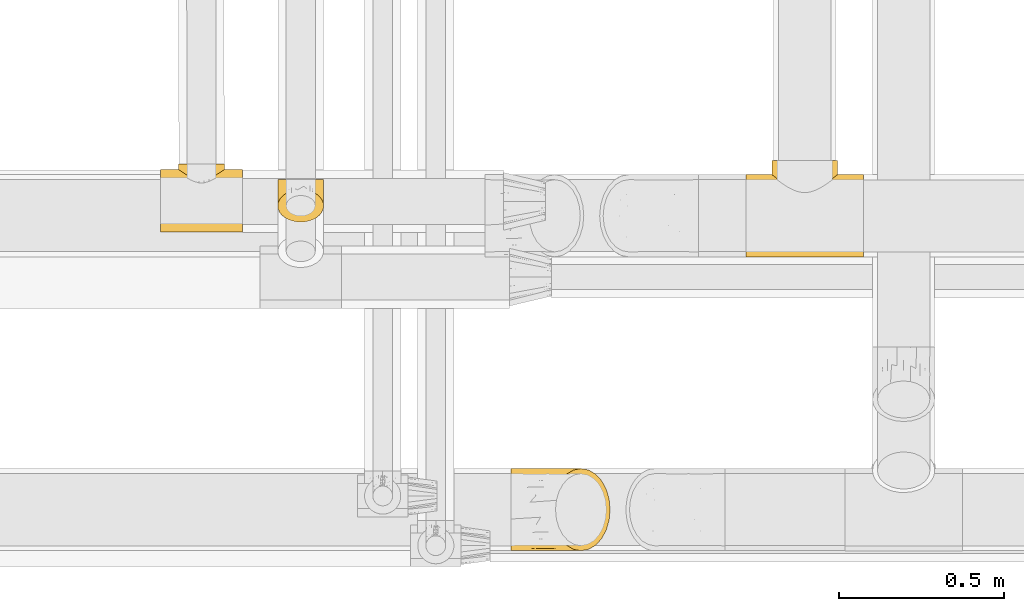
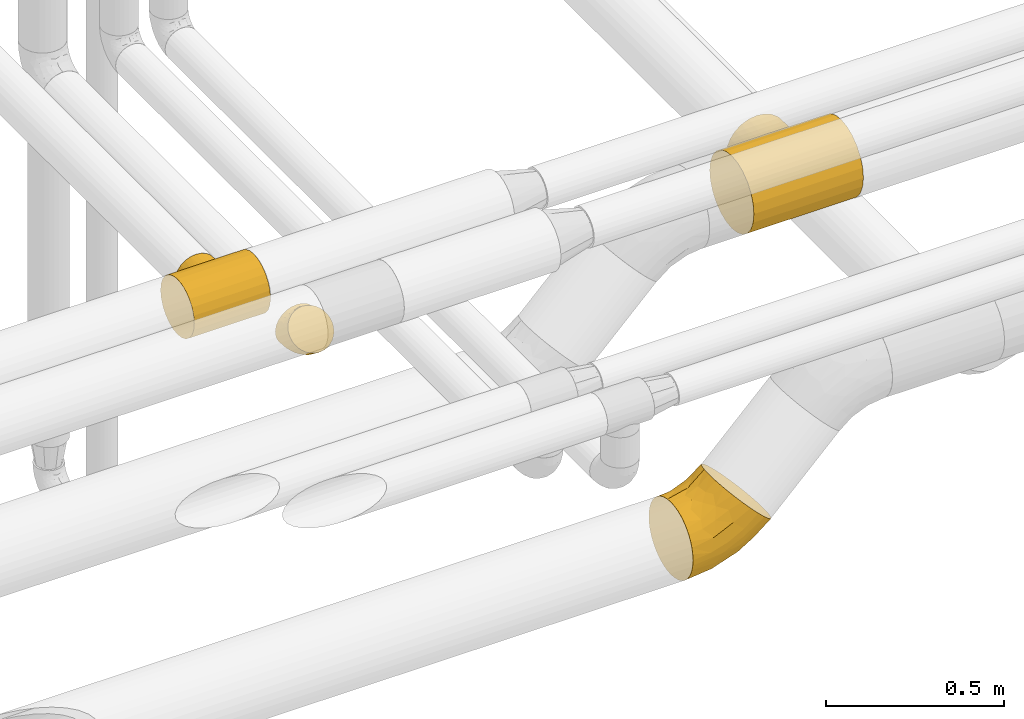
# One storey, part 185 of 827: 4 coverings.
"""IFC2X3 building model written with IfcOpenShell, lengths in millimetres."""

from ifc_helpers import new_model, entity, si_unit, converted_unit, derived_unit, direction, frame, origin, place, context, subcontext, project, spatial, faceted_brep, element, save


model = new_model("IFC2X3")

# Units and contexts
model_context = context("Model", 3, precision=0.01, world=origin(), true_north=direction((6.12303176911189e-17, 1.0)))
body_context = subcontext(model_context, "Body", "Model", "MODEL_VIEW")
ifc_project = project(units=[si_unit("LENGTHUNIT", "METRE", prefix="MILLI"), si_unit("AREAUNIT", "SQUARE_METRE"), si_unit("VOLUMEUNIT", "CUBIC_METRE"), converted_unit("PLANEANGLEUNIT", "DEGREE", entity("IfcRatioMeasure", 0.0174532925199433), si_unit("PLANEANGLEUNIT", "RADIAN"), dimensions=[0, 0, 0, 0, 0, 0, 0]), si_unit("MASSUNIT", "GRAM", prefix="KILO"), derived_unit("MASSDENSITYUNIT", [(si_unit("MASSUNIT", "GRAM", prefix="KILO"), 1), (si_unit("LENGTHUNIT", "METRE"), -3)]), derived_unit("MOMENTOFINERTIAUNIT", [(si_unit("LENGTHUNIT", "METRE"), 4)]), si_unit("TIMEUNIT", "SECOND"), si_unit("FREQUENCYUNIT", "HERTZ"), si_unit("THERMODYNAMICTEMPERATUREUNIT", "DEGREE_CELSIUS"), derived_unit("THERMALTRANSMITTANCEUNIT", [(si_unit("MASSUNIT", "GRAM", prefix="KILO"), 1), (si_unit("THERMODYNAMICTEMPERATUREUNIT", "KELVIN"), -1), (si_unit("TIMEUNIT", "SECOND"), -3)]), derived_unit("VOLUMETRICFLOWRATEUNIT", [(si_unit("LENGTHUNIT", "METRE"), 3), (si_unit("TIMEUNIT", "SECOND"), -1)]), derived_unit("MASSFLOWRATEUNIT", [(si_unit("MASSUNIT", "GRAM", prefix="KILO"), 1), (si_unit("TIMEUNIT", "SECOND"), -1)]), derived_unit("ROTATIONALFREQUENCYUNIT", [(si_unit("TIMEUNIT", "SECOND"), -1)]), si_unit("ELECTRICCURRENTUNIT", "AMPERE"), si_unit("ELECTRICVOLTAGEUNIT", "VOLT"), si_unit("POWERUNIT", "WATT"), si_unit("FORCEUNIT", "NEWTON", prefix="KILO"), si_unit("ILLUMINANCEUNIT", "LUX"), si_unit("LUMINOUSFLUXUNIT", "LUMEN"), si_unit("LUMINOUSINTENSITYUNIT", "CANDELA"), derived_unit("USERDEFINED", [(si_unit("MASSUNIT", "GRAM", prefix="KILO"), -1), (si_unit("LENGTHUNIT", "METRE"), -2), (si_unit("TIMEUNIT", "SECOND"), 3), (si_unit("LUMINOUSFLUXUNIT", "LUMEN"), 1)]), derived_unit("LINEARVELOCITYUNIT", [(si_unit("LENGTHUNIT", "METRE"), 1), (si_unit("TIMEUNIT", "SECOND"), -1)]), si_unit("PRESSUREUNIT", "PASCAL"), derived_unit("USERDEFINED", [(si_unit("LENGTHUNIT", "METRE"), -2), (si_unit("MASSUNIT", "GRAM", prefix="KILO"), 1), (si_unit("TIMEUNIT", "SECOND"), -2)]), derived_unit("LINEARFORCEUNIT", [(si_unit("MASSUNIT", "GRAM", prefix="KILO"), 1), (si_unit("LENGTHUNIT", "METRE"), 1), (si_unit("TIMEUNIT", "SECOND"), -2), (si_unit("LENGTHUNIT", "METRE"), -1)]), derived_unit("PLANARFORCEUNIT", [(si_unit("MASSUNIT", "GRAM", prefix="KILO"), 1), (si_unit("LENGTHUNIT", "METRE"), 1), (si_unit("TIMEUNIT", "SECOND"), -2), (si_unit("LENGTHUNIT", "METRE"), -2)])], contexts=[model_context])

# Site, building, storey
site_placement = place(None, origin())
site = spatial("IfcSite", under=ifc_project, at=site_placement, CompositionType="ELEMENT")
building_placement = place(site_placement, origin())
building = spatial("IfcBuilding", under=site, at=building_placement, CompositionType="ELEMENT")
storey_placement = place(building_placement, frame((0.0, 0.0, 28200.0)))
storey = spatial("IfcBuildingStorey", under=building, at=storey_placement, Name="08", CompositionType="ELEMENT", Elevation=28200.0)

# Coverings
covering_1_placement = place(storey_placement, frame((37570.29, 7140.06, 2773.76)))
element("IfcCovering", 1, at=covering_1_placement, inside=storey, Name=":ADSK_", ObjectType=":ADSK_", PredefinedType="INSULATION", context=body_context, shape_type="Brep", body=[
    faceted_brep([(0.0, 63.87, 18.29), (0.0, 38.08, 38.08), (0.0, 18.28, 63.88), (0.0, 5.84, 93.92), (0.0, 1.6, 126.15), (0.0, 5.84, 158.39), (0.0, 18.28, 188.43), (0.01, 38.08, 214.22), (0.01, 63.87, 234.02), (0.01, 93.91, 246.46), (0.01, 126.15, 250.7), (0.01, 158.38, 246.46), (0.01, 188.42, 234.02), (0.01, 214.22, 214.22), (0.01, 224.11, 201.33), (0.0, 234.01, 188.43), (0.0, 240.23, 173.41), (0.0, 246.45, 158.39), (0.0, 248.57, 142.27), (0.0, 250.7, 126.15), (0.0, 248.57, 110.04), (0.0, 246.45, 93.92), (0.0, 240.23, 78.9), (0.0, 234.01, 63.88), (0.0, 224.11, 50.98), (0.0, 214.22, 38.08), (0.0, 188.42, 18.29), (0.0, 158.38, 5.85), (0.0, 126.15, 1.6), (0.0, 93.91, 5.85), (356.01, 93.91, 246.45), (356.01, 63.87, 234.01), (356.01, 38.08, 214.22), (356.0, 18.28, 188.42), (356.0, 5.84, 158.38), (356.0, 1.6, 126.15), (356.0, 5.84, 93.91), (356.0, 18.28, 63.87), (356.0, 38.08, 38.08), (356.0, 63.87, 18.28), (356.0, 93.91, 5.84), (356.0, 126.15, 1.6), (356.0, 158.38, 5.84), (356.0, 188.42, 18.28), (356.0, 214.22, 38.08), (356.0, 224.11, 50.97), (356.0, 234.01, 63.87), (356.0, 240.23, 78.89), (356.0, 246.45, 93.91), (356.0, 248.57, 110.03), (356.0, 250.7, 126.15), (356.0, 248.57, 142.26), (356.0, 246.45, 158.38), (356.0, 240.23, 173.4), (356.0, 234.01, 188.42), (356.01, 224.11, 201.32), (356.01, 214.22, 214.22), (356.01, 188.42, 234.01), (356.01, 158.38, 246.45), (356.01, 126.15, 250.7), (194.3, 203.27, 223.95), (178.01, 201.52, 225.3), (209.64, 207.89, 220.12), (236.25, 221.41, 206.39), (223.62, 214.25, 214.18), (247.53, 228.69, 196.84), (90.44, 241.69, 172.66), (275.79, 249.61, 142.52), (161.71, 203.27, 223.95), (146.38, 207.89, 220.12), (78.85, 250.7, 126.15), (80.21, 249.61, 142.52), (132.39, 214.25, 214.18), (119.76, 221.41, 206.39), (108.48, 228.69, 196.84), (257.37, 235.6, 185.58), (265.57, 241.69, 172.65), (277.15, 250.7, 126.15), (271.83, 246.5, 158.2), (98.64, 235.6, 185.58), (84.18, 246.5, 158.2), (271.83, 246.5, 94.1), (275.79, 249.61, 109.77), (257.37, 235.6, 66.72), (265.57, 241.69, 79.64), (247.52, 228.69, 55.46), (80.21, 249.61, 109.78), (84.18, 246.5, 94.1), (98.64, 235.6, 66.72), (108.48, 228.69, 55.46), (90.43, 241.69, 79.65), (236.25, 221.41, 45.91), (223.62, 214.25, 38.12), (209.63, 207.89, 32.18), (194.29, 203.27, 28.35), (178.0, 201.52, 27.0), (119.76, 221.41, 45.91), (132.38, 214.25, 38.12), (146.37, 207.89, 32.18), (161.71, 203.27, 28.35), (263.87, 294.15, 175.72), (273.78, 294.15, 151.81), (277.15, 294.15, 126.15), (273.77, 294.15, 100.49), (263.87, 294.15, 76.57), (248.11, 294.15, 56.04), (227.58, 294.15, 40.28), (203.66, 294.15, 30.38), (178.0, 294.15, 27.0), (152.34, 294.15, 30.38), (128.43, 294.15, 40.28), (107.89, 294.15, 56.04), (92.14, 294.15, 76.58), (82.23, 294.15, 100.49), (78.85, 294.15, 126.15), (82.23, 294.15, 151.81), (92.14, 294.15, 175.73), (107.9, 294.15, 196.26), (128.43, 294.15, 212.02), (152.34, 294.15, 221.92), (178.01, 294.15, 225.3), (203.67, 294.15, 221.92), (227.58, 294.15, 212.02), (248.11, 294.15, 196.26)], [[[0, 1, 2, 3, 4, 5, 6, 7, 8, 9, 10, 11, 12, 13, 14, 15, 16, 17, 18, 19, 20, 21, 22, 23, 24, 25, 26, 27, 28, 29]], [[30, 31, 32, 33, 34, 35, 36, 37, 38, 39, 40, 41, 42, 43, 44, 45, 46, 47, 48, 49, 50, 51, 52, 53, 54, 55, 56, 57, 58, 59]], [[6, 33, 32, 7]], [[4, 35, 34, 5]], [[5, 34, 33, 6]], [[8, 31, 30, 9]], [[9, 30, 59, 10]], [[7, 32, 31, 8]], [[11, 58, 57, 12]], [[60, 61, 57]], [[58, 11, 10, 59]], [[57, 62, 60]], [[56, 63, 64]], [[56, 55, 63]], [[63, 55, 65]], [[64, 62, 56]], [[66, 17, 16]], [[56, 62, 57]], [[67, 52, 51]], [[57, 61, 12]], [[61, 68, 12]], [[69, 13, 12]], [[70, 18, 71]], [[13, 72, 73]], [[72, 13, 69]], [[74, 15, 14]], [[73, 74, 14]], [[75, 53, 76]], [[69, 12, 68]], [[53, 75, 54]], [[76, 53, 52]], [[75, 65, 54]], [[54, 65, 55]], [[50, 77, 51]], [[18, 70, 19]], [[67, 78, 52]], [[67, 51, 77]], [[52, 78, 76]], [[74, 79, 15]], [[79, 16, 15]], [[16, 79, 66]], [[14, 13, 73]], [[80, 71, 17]], [[71, 18, 17]], [[80, 17, 66]], [[50, 49, 77]], [[70, 20, 19]], [[48, 81, 82]], [[82, 49, 48]], [[46, 83, 47]], [[84, 47, 83]], [[46, 85, 83]], [[48, 84, 81]], [[70, 86, 20]], [[86, 87, 21]], [[23, 88, 89]], [[21, 90, 22]], [[90, 21, 87]], [[22, 88, 23]], [[44, 91, 45]], [[91, 44, 92]], [[93, 92, 44]], [[44, 43, 93]], [[84, 48, 47]], [[26, 43, 42, 27]], [[94, 43, 95]], [[43, 94, 93]], [[26, 95, 43]], [[86, 21, 20]], [[42, 41, 28, 27]], [[96, 24, 89]], [[96, 97, 25]], [[85, 46, 45]], [[89, 24, 23]], [[24, 96, 25]], [[97, 98, 25]], [[98, 99, 26]], [[77, 49, 82]], [[95, 26, 99]], [[98, 26, 25]], [[88, 22, 90]], [[85, 45, 91]], [[29, 40, 39, 0]], [[0, 39, 38, 1]], [[41, 40, 29, 28]], [[2, 37, 36, 3]], [[3, 36, 35, 4]], [[1, 38, 37, 2]], [[100, 101, 102, 103, 104, 105, 106, 107, 108, 109, 110, 111, 112, 113, 114, 115, 116, 117, 118, 119, 120, 121, 122, 123]], [[67, 102, 101]], [[100, 123, 75]], [[78, 101, 100]], [[67, 77, 102]], [[76, 78, 100]], [[75, 76, 100]], [[67, 101, 78]], [[123, 65, 75]], [[65, 123, 63]], [[63, 123, 122]], [[64, 122, 121]], [[60, 121, 120]], [[63, 122, 64]], [[121, 60, 62]], [[62, 64, 121]], [[60, 120, 61]], [[68, 120, 119]], [[119, 118, 72]], [[117, 73, 118]], [[117, 74, 73]], [[61, 120, 68]], [[69, 68, 119]], [[119, 72, 69]], [[118, 73, 72]], [[79, 117, 116]], [[80, 116, 115]], [[71, 115, 114]], [[66, 79, 116]], [[71, 80, 115]], [[70, 71, 114]], [[66, 116, 80]], [[117, 79, 74]], [[86, 114, 113]], [[87, 113, 112]], [[88, 112, 111]], [[86, 70, 114]], [[90, 87, 112]], [[88, 90, 112]], [[86, 113, 87]], [[111, 89, 88]], [[89, 111, 96]], [[96, 111, 110]], [[97, 110, 109]], [[99, 109, 108]], [[96, 110, 97]], [[109, 99, 98]], [[98, 97, 109]], [[99, 108, 95]], [[94, 108, 107]], [[107, 106, 92]], [[105, 91, 106]], [[105, 85, 91]], [[95, 108, 94]], [[93, 94, 107]], [[107, 92, 93]], [[106, 91, 92]], [[83, 105, 104]], [[81, 104, 103]], [[82, 103, 102]], [[84, 83, 104]], [[82, 81, 103]], [[77, 82, 102]], [[84, 104, 81]], [[105, 83, 85]]]),
])
covering_2_placement = place(storey_placement, frame((36148.99, 7245.63, 2778.95)))
element("IfcCovering", 2, at=covering_2_placement, inside=storey, Name=":ADSK_", ObjectType=":ADSK_", PredefinedType="INSULATION", context=body_context, shape_type="Brep", body=[
    faceted_brep([(44.46, 96.07, 149.8), (32.45, 91.53, 145.26), (21.93, 85.42, 139.16), (13.29, 77.98, 131.71), (6.88, 69.49, 123.22), (2.93, 60.28, 114.01), (1.6, 50.7, 104.44), (2.93, 41.12, 94.85), (6.88, 31.91, 85.64), (13.3, 23.42, 77.15), (21.94, 15.97, 69.71), (32.47, 9.87, 63.6), (44.48, 5.33, 59.06), (57.5, 2.54, 56.27), (71.05, 1.6, 55.33), (84.6, 2.54, 56.27), (97.63, 5.34, 59.07), (109.64, 9.87, 63.61), (120.16, 15.98, 69.71), (128.8, 23.43, 77.16), (135.21, 31.92, 85.65), (139.16, 41.13, 94.86), (140.5, 50.7, 104.44), (139.16, 60.29, 114.02), (135.21, 69.5, 123.23), (128.79, 77.99, 131.72), (120.15, 85.43, 139.16), (109.62, 91.54, 145.27), (97.62, 96.08, 149.81), (84.59, 98.87, 152.6), (71.05, 99.81, 153.54), (57.49, 98.87, 152.6), (71.05, 131.31, 140.5), (89.02, 131.31, 138.13), (105.77, 131.31, 131.19), (120.15, 131.31, 120.15), (131.19, 131.31, 105.77), (138.13, 131.31, 89.02), (140.5, 131.31, 71.05), (138.13, 131.31, 53.07), (131.19, 131.31, 36.32), (120.15, 131.31, 21.94), (105.77, 131.31, 10.9), (89.02, 131.31, 3.96), (71.05, 131.31, 1.6), (53.07, 131.31, 3.96), (36.32, 131.31, 10.9), (21.94, 131.31, 21.94), (10.9, 131.31, 36.32), (3.96, 131.31, 53.07), (1.6, 131.31, 71.05), (3.96, 131.31, 89.02), (10.9, 131.31, 105.77), (21.94, 131.31, 120.15), (36.32, 131.31, 131.19), (53.07, 131.31, 138.13), (10.96, 88.93, 42.38), (71.05, 83.83, 7.85), (58.64, 99.89, 5.44), (29.89, 95.08, 19.01), (45.12, 97.97, 9.76), (55.8, 68.52, 14.48), (18.48, 100.53, 28.65), (19.3, 67.5, 37.97), (51.71, 34.21, 32.65), (40.19, 63.13, 22.55), (4.96, 79.52, 60.0), (29.3, 66.5, 28.42), (1.6, 74.31, 86.32), (1.6, 88.06, 80.62), (1.6, 101.81, 74.93), (10.82, 54.57, 57.81), (1.6, 115.28, 73.16), (18.25, 40.23, 54.57), (28.13, 40.29, 43.13), (39.32, 35.5, 37.67), (71.05, 39.59, 26.17), (1.6, 62.51, 95.38), (3.1, 83.48, 97.66), (4.91, 115.07, 93.69), (12.3, 101.86, 113.94), (14.54, 90.93, 123.49), (24.31, 98.32, 131.81), (3.76, 96.7, 94.66), (22.31, 111.85, 123.53), (34.74, 109.92, 134.6), (7.16, 84.35, 112.1), (58.74, 120.06, 140.81), (45.08, 119.55, 136.87), (49.04, 108.29, 142.78), (71.05, 114.27, 143.89), (3.24, 72.24, 105.61), (13.98, 117.58, 111.91), (83.34, 120.07, 140.8), (93.04, 108.29, 142.78), (97.0, 119.55, 136.88), (134.92, 84.36, 112.12), (138.99, 83.5, 97.68), (138.32, 96.72, 94.67), (140.5, 88.06, 80.62), (117.77, 98.33, 131.82), (119.76, 111.86, 123.55), (107.33, 109.92, 134.61), (137.18, 115.07, 93.69), (140.5, 115.28, 73.16), (128.1, 117.57, 111.92), (129.78, 101.87, 113.96), (138.85, 72.25, 105.62), (127.38, 89.86, 124.49), (140.5, 62.51, 95.38), (140.5, 101.81, 74.93), (140.5, 74.31, 86.32), (131.27, 54.58, 57.82), (131.13, 88.9, 42.39), (137.13, 79.52, 60.0), (113.98, 40.3, 43.13), (113.47, 66.86, 28.83), (122.8, 67.52, 37.98), (112.2, 95.1, 19.01), (123.62, 100.55, 28.66), (83.46, 99.94, 5.43), (86.3, 68.54, 14.48), (96.98, 97.96, 9.77), (123.85, 40.24, 54.58), (101.92, 63.13, 22.56), (90.4, 34.21, 32.65), (102.85, 29.15, 42.06)], [[[0, 1, 2, 3, 4, 5, 6, 7, 8, 9, 10, 11, 12, 13, 14, 15, 16, 17, 18, 19, 20, 21, 22, 23, 24, 25, 26, 27, 28, 29, 30, 31]], [[32, 33, 34, 35, 36, 37, 38, 39, 40, 41, 42, 43, 44, 45, 46, 47, 48, 49, 50, 51, 52, 53, 54, 55]], [[49, 48, 56]], [[44, 57, 58]], [[59, 46, 60]], [[61, 60, 58]], [[62, 63, 56]], [[61, 64, 65]], [[46, 59, 47]], [[8, 7, 66]], [[63, 62, 67]], [[66, 68, 69, 70]], [[9, 8, 71]], [[49, 70, 72, 50]], [[70, 49, 66]], [[73, 74, 10]], [[63, 71, 56]], [[75, 65, 64]], [[64, 61, 76]], [[76, 13, 64]], [[73, 10, 9]], [[75, 74, 67]], [[75, 11, 74]], [[13, 76, 14]], [[61, 65, 60]], [[62, 48, 47]], [[61, 58, 57]], [[49, 56, 66]], [[56, 71, 66]], [[7, 6, 77, 68]], [[71, 63, 73]], [[68, 66, 7]], [[67, 59, 65]], [[74, 73, 63]], [[74, 11, 10]], [[71, 73, 9]], [[59, 67, 62]], [[64, 13, 12]], [[76, 61, 57]], [[8, 66, 71]], [[59, 60, 65]], [[45, 60, 46]], [[48, 62, 56]], [[59, 62, 47]], [[60, 45, 58]], [[44, 58, 45]], [[64, 12, 75]], [[11, 75, 12]], [[75, 67, 65]], [[63, 67, 74]], [[69, 68, 78]], [[70, 79, 72]], [[80, 81, 82]], [[79, 70, 83]], [[54, 84, 85]], [[84, 82, 85]], [[83, 86, 80]], [[82, 84, 80]], [[87, 32, 55]], [[88, 85, 89]], [[78, 86, 83]], [[0, 31, 89]], [[85, 88, 54]], [[31, 90, 89]], [[86, 78, 91]], [[92, 84, 53]], [[82, 1, 85]], [[82, 81, 2]], [[81, 80, 86]], [[86, 91, 4]], [[77, 5, 91]], [[88, 87, 55]], [[80, 92, 79]], [[77, 6, 5]], [[92, 80, 84]], [[30, 90, 31]], [[54, 53, 84]], [[0, 85, 1]], [[82, 2, 1]], [[52, 51, 79]], [[89, 85, 0]], [[4, 91, 5]], [[80, 79, 83]], [[3, 86, 4]], [[53, 52, 92]], [[51, 72, 79]], [[79, 92, 52]], [[78, 83, 69]], [[68, 91, 78]], [[91, 68, 77]], [[87, 89, 90]], [[54, 88, 55]], [[89, 87, 88]], [[32, 87, 90]], [[51, 50, 72]], [[86, 3, 81]], [[2, 81, 3]], [[83, 70, 69]], [[93, 94, 95]], [[95, 34, 33]], [[90, 93, 32]], [[96, 97, 98]], [[97, 99, 98]], [[100, 101, 102]], [[103, 104, 37]], [[105, 101, 106]], [[98, 103, 106]], [[96, 107, 97]], [[102, 101, 34]], [[103, 37, 36]], [[90, 29, 94]], [[106, 108, 96]], [[94, 29, 28]], [[103, 105, 106]], [[94, 28, 102]], [[24, 96, 25]], [[35, 101, 105]], [[27, 26, 100]], [[25, 96, 108]], [[27, 100, 102]], [[107, 24, 23]], [[27, 102, 28]], [[100, 108, 106]], [[106, 96, 98]], [[95, 94, 102]], [[101, 100, 106]], [[23, 109, 107]], [[107, 96, 24]], [[34, 95, 102]], [[26, 25, 108]], [[103, 36, 105]], [[29, 90, 30]], [[110, 103, 98]], [[34, 101, 35]], [[36, 35, 105]], [[107, 111, 97]], [[109, 23, 22]], [[109, 111, 107]], [[93, 95, 33]], [[32, 93, 33]], [[94, 93, 90]], [[104, 103, 110]], [[104, 38, 37]], [[26, 108, 100]], [[99, 97, 111]], [[99, 110, 98]], [[112, 113, 114]], [[115, 116, 117]], [[118, 42, 41]], [[119, 40, 113]], [[114, 110, 99, 111]], [[39, 38, 104, 110]], [[119, 118, 41]], [[39, 114, 113]], [[43, 120, 44]], [[121, 120, 122]], [[42, 122, 43]], [[39, 113, 40]], [[19, 18, 123]], [[121, 122, 124]], [[76, 121, 125]], [[118, 124, 122]], [[21, 114, 111]], [[119, 113, 117]], [[39, 110, 114]], [[115, 123, 18]], [[18, 17, 115]], [[113, 112, 117]], [[116, 124, 118]], [[19, 123, 112]], [[114, 20, 112]], [[115, 117, 123]], [[125, 121, 124]], [[16, 125, 126]], [[15, 14, 76]], [[15, 76, 125]], [[112, 20, 19]], [[124, 115, 126]], [[121, 76, 57]], [[15, 125, 16]], [[17, 16, 126]], [[21, 111, 109, 22]], [[112, 123, 117]], [[21, 20, 114]], [[121, 57, 120]], [[118, 122, 42]], [[119, 117, 116]], [[40, 119, 41]], [[44, 120, 57]], [[43, 122, 120]], [[124, 126, 125]], [[17, 126, 115]], [[124, 116, 115]], [[119, 116, 118]]]),
])
covering_3_placement = place(storey_placement, frame((36856.37, 6248.9, 2373.9)))
element("IfcCovering", 3, at=covering_3_placement, inside=storey, Name=":ADSK_", ObjectType=":ADSK_", PredefinedType="INSULATION", context=body_context, shape_type="Brep", body=[
    faceted_brep([(1.6, 106.63, 249.06), (1.6, 126.1, 250.6), (1.6, 145.57, 249.06), (1.6, 164.57, 244.5), (1.6, 182.62, 237.02), (1.6, 199.28, 226.82), (1.6, 214.13, 214.13), (1.6, 226.82, 199.27), (1.6, 237.03, 182.61), (1.6, 244.5, 164.56), (1.6, 249.06, 145.56), (1.6, 250.6, 126.1), (1.6, 249.06, 106.62), (1.6, 244.5, 87.62), (1.6, 237.02, 69.57), (1.6, 226.82, 52.91), (1.6, 214.13, 38.06), (1.6, 199.27, 25.37), (1.6, 182.61, 15.16), (1.6, 164.56, 7.69), (1.6, 145.56, 3.13), (1.6, 126.1, 1.6), (1.6, 106.62, 3.13), (1.6, 87.62, 7.69), (1.6, 69.57, 15.17), (1.6, 52.91, 25.37), (1.6, 38.06, 38.06), (1.6, 25.37, 52.92), (1.6, 15.16, 69.58), (1.6, 7.69, 87.63), (1.6, 3.13, 106.63), (1.6, 1.6, 126.1), (1.6, 3.13, 145.57), (1.6, 7.69, 164.57), (1.6, 15.17, 182.62), (1.6, 25.37, 199.28), (1.6, 38.06, 214.13), (1.6, 52.92, 226.82), (1.6, 69.58, 237.03), (1.6, 87.63, 244.5), (128.69, 93.87, 299.0), (137.49, 63.85, 290.2), (151.48, 38.06, 276.21), (169.71, 18.28, 257.98), (190.94, 5.84, 236.75), (213.73, 1.6, 213.96), (236.51, 5.84, 191.18), (257.74, 18.28, 169.95), (275.98, 38.06, 151.71), (289.97, 63.85, 137.72), (298.76, 93.87, 128.93), (301.76, 126.1, 125.93), (298.76, 158.32, 128.93), (289.97, 188.35, 137.72), (275.98, 214.13, 151.71), (257.74, 233.92, 169.95), (236.51, 246.35, 191.18), (213.73, 250.6, 213.96), (190.94, 246.35, 236.75), (169.71, 233.92, 257.98), (151.48, 214.13, 276.21), (137.49, 188.35, 290.2), (128.69, 158.32, 299.0), (125.69, 126.1, 302.0), (227.53, 149.06, 69.24), (162.5, 157.57, 37.65), (232.64, 172.62, 80.78), (251.11, 126.1, 82.67), (87.27, 172.54, 19.51), (88.51, 205.38, 39.76), (72.31, 228.86, 62.63), (169.79, 211.39, 73.47), (132.77, 126.1, 22.37), (194.31, 126.1, 47.86), (68.0, 126.1, 6.82), (94.6, 148.92, 14.07), (224.14, 196.14, 90.2), (156.46, 188.53, 48.93), (159.73, 241.93, 118.76), (81.73, 239.97, 85.05), (98.75, 247.93, 115.3), (213.5, 224.58, 115.31), (141.47, 229.78, 84.73), (164.84, 248.4, 147.07), (116.4, 250.6, 148.93), (168.27, 250.6, 176.65), (60.12, 250.6, 131.86), (144.59, 243.25, 211.5), (102.29, 247.16, 174.55), (94.09, 237.03, 200.86), (105.15, 219.17, 235.05), (127.13, 232.82, 226.38), (45.11, 175.8, 245.41), (69.55, 148.67, 262.05), (92.2, 170.51, 266.31), (54.34, 243.33, 173.44), (107.8, 189.91, 264.83), (76.0, 195.3, 244.22), (38.6, 195.29, 233.11), (89.35, 126.1, 274.11), (53.39, 223.78, 209.38), (47.02, 126.1, 256.58), (56.49, 99.35, 256.34), (95.02, 94.07, 272.6), (135.65, 8.49, 204.31), (116.4, 1.6, 148.93), (168.27, 1.6, 176.65), (131.4, 25.02, 239.5), (87.85, 26.42, 217.85), (101.5, 48.04, 249.38), (50.41, 42.36, 224.04), (74.53, 74.96, 254.46), (36.95, 76.79, 243.81), (108.87, 73.49, 272.73), (74.09, 8.09, 176.09), (45.75, 25.62, 203.96), (60.12, 1.6, 131.86), (159.72, 10.26, 118.76), (213.49, 27.6, 115.31), (169.79, 40.79, 73.47), (224.16, 56.04, 90.22), (164.83, 3.79, 147.07), (98.75, 4.26, 115.3), (227.52, 103.13, 69.24), (88.51, 46.81, 39.76), (156.45, 63.66, 48.94), (232.65, 79.57, 80.78), (162.5, 94.61, 37.65), (141.47, 22.4, 84.73), (94.58, 103.26, 14.07), (87.27, 79.64, 19.51), (72.31, 23.32, 62.64), (81.73, 12.22, 85.06)], [[[0, 1, 2, 3, 4, 5, 6, 7, 8, 9, 10, 11, 12, 13, 14, 15, 16, 17, 18, 19, 20, 21, 22, 23, 24, 25, 26, 27, 28, 29, 30, 31, 32, 33, 34, 35, 36, 37, 38, 39]], [[40, 41, 42, 43, 44, 45, 46, 47, 48, 49, 50, 51, 52, 53, 54, 55, 56, 57, 58, 59, 60, 61, 62, 63]], [[64, 65, 66]], [[67, 52, 51]], [[68, 18, 17]], [[69, 70, 71]], [[72, 65, 73]], [[72, 74, 75]], [[17, 16, 69]], [[64, 73, 65]], [[70, 16, 15]], [[76, 66, 77]], [[78, 79, 80]], [[55, 81, 78]], [[78, 82, 79]], [[80, 13, 12]], [[76, 77, 71]], [[57, 56, 83]], [[78, 80, 83]], [[68, 69, 77]], [[77, 69, 71]], [[84, 85, 83]], [[18, 68, 19]], [[77, 65, 68]], [[69, 68, 17]], [[75, 68, 65]], [[78, 81, 82]], [[70, 69, 16]], [[68, 75, 19]], [[20, 74, 21]], [[53, 66, 76]], [[76, 71, 81]], [[54, 76, 81]], [[54, 81, 55]], [[86, 12, 11]], [[84, 80, 86]], [[80, 84, 83]], [[53, 52, 66]], [[64, 52, 67]], [[82, 70, 79]], [[81, 71, 82]], [[86, 80, 12]], [[76, 54, 53]], [[79, 14, 13]], [[14, 79, 70]], [[55, 78, 56]], [[77, 66, 65]], [[75, 20, 19]], [[72, 75, 65]], [[80, 79, 13]], [[20, 75, 74]], [[70, 82, 71]], [[14, 70, 15]], [[57, 83, 85]], [[56, 78, 83]], [[52, 64, 66]], [[73, 64, 67]], [[58, 85, 87]], [[58, 57, 85]], [[87, 85, 88]], [[89, 90, 91]], [[91, 60, 59]], [[91, 87, 89]], [[92, 93, 94]], [[2, 93, 92]], [[88, 95, 89]], [[96, 97, 94]], [[94, 97, 92]], [[98, 6, 5]], [[88, 85, 84]], [[99, 63, 62]], [[93, 62, 94]], [[61, 94, 62]], [[98, 4, 92]], [[2, 92, 3]], [[100, 8, 7]], [[87, 88, 89]], [[7, 6, 100]], [[100, 95, 8]], [[10, 95, 86]], [[98, 100, 6]], [[90, 97, 96]], [[9, 95, 10]], [[11, 10, 86]], [[93, 101, 99]], [[4, 98, 5]], [[62, 93, 99]], [[59, 58, 87]], [[1, 101, 2]], [[93, 2, 101]], [[86, 95, 88]], [[100, 90, 89]], [[4, 3, 92]], [[95, 100, 89]], [[90, 96, 60]], [[92, 97, 98]], [[90, 100, 97]], [[100, 98, 97]], [[9, 8, 95]], [[94, 61, 96]], [[86, 88, 84]], [[96, 61, 60]], [[60, 91, 90]], [[59, 87, 91]], [[102, 103, 99]], [[104, 105, 106]], [[102, 99, 101]], [[104, 107, 108]], [[109, 107, 42]], [[103, 63, 99]], [[110, 111, 112]], [[109, 111, 110]], [[0, 102, 101]], [[113, 103, 111]], [[114, 104, 108]], [[45, 44, 106]], [[104, 44, 43]], [[41, 109, 42]], [[109, 108, 107]], [[106, 44, 104]], [[104, 43, 107]], [[104, 114, 105]], [[0, 39, 102]], [[34, 115, 35]], [[115, 34, 114]], [[43, 42, 107]], [[38, 112, 39]], [[39, 112, 102]], [[37, 110, 112]], [[113, 40, 103]], [[115, 110, 36]], [[35, 115, 36]], [[116, 114, 33]], [[37, 36, 110]], [[110, 115, 108]], [[114, 34, 33]], [[109, 110, 108]], [[114, 116, 105]], [[112, 111, 102]], [[102, 111, 103]], [[32, 31, 116]], [[33, 32, 116]], [[113, 109, 41]], [[112, 38, 37]], [[109, 113, 111]], [[0, 101, 1]], [[40, 113, 41]], [[103, 40, 63]], [[114, 108, 115]], [[117, 47, 46]], [[117, 118, 47]], [[118, 119, 120]], [[121, 122, 117]], [[73, 67, 123]], [[119, 124, 125]], [[122, 121, 105]], [[106, 121, 45]], [[123, 126, 127]], [[118, 128, 119]], [[67, 51, 50]], [[129, 130, 23]], [[48, 120, 49]], [[125, 127, 126]], [[50, 126, 123]], [[73, 127, 72]], [[23, 22, 129]], [[131, 119, 128]], [[126, 50, 49]], [[130, 24, 23]], [[28, 132, 29]], [[126, 49, 120]], [[116, 31, 30]], [[131, 26, 124]], [[118, 48, 47]], [[132, 122, 29]], [[132, 131, 128]], [[121, 106, 105]], [[117, 128, 118]], [[131, 28, 27]], [[125, 126, 120]], [[124, 26, 25]], [[124, 25, 130]], [[130, 25, 24]], [[30, 122, 116]], [[129, 22, 74]], [[127, 130, 129]], [[132, 117, 122]], [[21, 74, 22]], [[127, 125, 130]], [[124, 130, 125]], [[127, 129, 72]], [[122, 105, 116]], [[48, 118, 120]], [[132, 128, 117]], [[29, 122, 30]], [[120, 119, 125]], [[119, 131, 124]], [[72, 129, 74]], [[28, 131, 132]], [[131, 27, 26]], [[117, 46, 121]], [[45, 121, 46]], [[73, 123, 127]], [[50, 123, 67]]]),
])
covering_4_placement = place(storey_placement, frame((35795.07, 7215.29, 3003.55)))
element("IfcCovering", 4, at=covering_4_placement, inside=storey, Name=":ADSK_", ObjectType=":ADSK_", PredefinedType="INSULATION", context=body_context, shape_type="Brep", body=[
    faceted_brep([(248.0, 49.02, 178.59), (248.0, 29.38, 163.51), (248.0, 14.3, 143.87), (248.0, 4.83, 120.99), (248.0, 1.6, 96.45), (248.0, 4.83, 71.9), (248.0, 14.3, 49.02), (248.0, 29.38, 29.38), (248.0, 49.02, 14.3), (248.0, 71.9, 4.83), (248.0, 96.45, 1.6), (248.0, 120.99, 4.83), (248.0, 143.87, 14.3), (248.0, 163.51, 29.38), (248.0, 171.05, 39.2), (248.0, 178.59, 49.02), (248.0, 183.33, 60.46), (248.0, 188.06, 71.9), (248.0, 189.68, 84.17), (248.0, 191.3, 96.45), (248.0, 189.68, 108.72), (248.0, 188.06, 120.99), (248.0, 183.33, 132.43), (248.0, 178.59, 143.87), (248.0, 171.05, 153.69), (248.0, 163.51, 163.51), (248.0, 143.87, 178.59), (248.0, 120.99, 188.06), (248.0, 96.45, 191.3), (248.0, 71.9, 188.06), (0.0, 29.38, 29.38), (0.0, 14.3, 49.02), (0.0, 4.83, 71.9), (0.0, 1.6, 96.45), (0.0, 4.83, 120.99), (0.0, 14.3, 143.87), (0.0, 29.38, 163.51), (0.0, 49.02, 178.59), (0.0, 71.9, 188.06), (0.0, 96.45, 191.3), (0.0, 120.99, 188.06), (0.0, 143.87, 178.59), (0.0, 163.51, 163.51), (0.0, 171.05, 153.69), (0.0, 178.59, 143.87), (0.0, 183.33, 132.43), (0.0, 188.06, 120.99), (0.0, 189.68, 108.72), (0.0, 191.3, 96.45), (0.0, 189.68, 84.17), (0.0, 188.06, 71.9), (0.0, 183.33, 60.46), (0.0, 178.59, 49.02), (0.0, 171.05, 39.2), (0.0, 163.51, 29.38), (0.0, 143.87, 14.3), (0.0, 120.99, 4.83), (0.0, 96.45, 1.6), (0.0, 71.9, 4.83), (0.0, 49.02, 14.3), (96.88, 166.51, 32.51), (75.14, 177.44, 47.09), (187.82, 187.26, 69.06), (181.31, 182.8, 57.22), (109.93, 162.56, 28.44), (85.25, 171.78, 38.81), (124.0, 161.05, 27.0), (138.07, 162.56, 28.44), (151.12, 166.51, 32.51), (193.45, 191.3, 96.45), (192.0, 190.24, 82.33), (162.75, 171.78, 38.81), (172.86, 177.44, 47.09), (66.69, 182.8, 57.22), (56.0, 190.24, 82.33), (60.18, 187.26, 69.06), (54.55, 191.3, 96.45), (56.0, 190.24, 110.56), (66.69, 182.8, 135.67), (60.18, 187.26, 123.83), (75.14, 177.44, 145.8), (192.0, 190.24, 110.56), (187.82, 187.26, 123.83), (181.31, 182.8, 135.67), (172.86, 177.44, 145.8), (96.88, 166.51, 160.38), (85.25, 171.78, 154.08), (109.93, 162.56, 164.45), (124.0, 161.05, 165.9), (151.12, 166.51, 160.38), (162.75, 171.78, 154.08), (138.07, 162.56, 164.45), (74.89, 207.45, 47.34), (63.85, 207.45, 61.72), (56.92, 207.45, 78.47), (54.55, 207.45, 96.45), (56.92, 207.45, 114.42), (63.85, 207.45, 131.17), (74.89, 207.45, 145.55), (89.27, 207.45, 156.59), (106.03, 207.45, 163.53), (124.0, 207.45, 165.9), (141.97, 207.45, 163.53), (158.72, 207.45, 156.59), (173.11, 207.45, 145.55), (184.15, 207.45, 131.17), (191.08, 207.45, 114.42), (193.45, 207.45, 96.45), (191.08, 207.45, 78.47), (184.15, 207.45, 61.72), (173.11, 207.45, 47.34), (158.72, 207.45, 36.3), (141.97, 207.45, 29.36), (124.0, 207.45, 27.0), (106.03, 207.45, 29.36), (89.27, 207.45, 36.3)], [[[0, 1, 2, 3, 4, 5, 6, 7, 8, 9, 10, 11, 12, 13, 14, 15, 16, 17, 18, 19, 20, 21, 22, 23, 24, 25, 26, 27, 28, 29]], [[30, 31, 32, 33, 34, 35, 36, 37, 38, 39, 40, 41, 42, 43, 44, 45, 46, 47, 48, 49, 50, 51, 52, 53, 54, 55, 56, 57, 58, 59]], [[31, 30, 7, 6]], [[4, 33, 32, 5]], [[5, 32, 31, 6]], [[8, 59, 58, 9]], [[9, 58, 57, 10]], [[7, 30, 59, 8]], [[56, 11, 10, 57]], [[55, 12, 11, 56]], [[53, 60, 54]], [[53, 52, 61]], [[62, 16, 63]], [[60, 64, 54]], [[60, 53, 65]], [[55, 54, 66]], [[54, 64, 66]], [[55, 66, 12]], [[66, 13, 12]], [[67, 68, 13]], [[69, 18, 70]], [[68, 14, 13]], [[14, 68, 71]], [[72, 14, 71]], [[67, 13, 66]], [[73, 52, 51]], [[74, 50, 49]], [[51, 75, 73]], [[75, 51, 50]], [[73, 61, 52]], [[61, 65, 53]], [[48, 76, 49]], [[69, 19, 18]], [[74, 49, 76]], [[50, 74, 75]], [[72, 63, 15]], [[16, 62, 17]], [[63, 16, 15]], [[15, 14, 72]], [[18, 17, 70]], [[70, 17, 62]], [[48, 47, 76]], [[19, 69, 20]], [[77, 47, 46]], [[45, 44, 78]], [[79, 46, 45]], [[44, 80, 78]], [[46, 79, 77]], [[81, 20, 69]], [[81, 82, 21]], [[23, 83, 84]], [[22, 82, 83]], [[82, 22, 21]], [[43, 80, 44]], [[43, 85, 86]], [[85, 43, 42]], [[79, 45, 78]], [[87, 85, 42]], [[42, 88, 87]], [[81, 21, 20]], [[26, 41, 40, 27]], [[26, 88, 41]], [[41, 88, 42]], [[40, 39, 28, 27]], [[89, 24, 90]], [[89, 25, 24]], [[76, 47, 77]], [[24, 84, 90]], [[84, 24, 23]], [[89, 91, 25]], [[80, 43, 86]], [[88, 25, 91]], [[88, 26, 25]], [[83, 23, 22]], [[29, 38, 37, 0]], [[0, 37, 36, 1]], [[39, 38, 29, 28]], [[2, 35, 34, 3]], [[3, 34, 33, 4]], [[1, 36, 35, 2]], [[92, 93, 94, 95, 96, 97, 98, 99, 100, 101, 102, 103, 104, 105, 106, 107, 108, 109, 110, 111, 112, 113, 114, 115]], [[74, 95, 94]], [[94, 93, 75]], [[92, 73, 93]], [[74, 76, 95]], [[73, 75, 93]], [[74, 94, 75]], [[92, 61, 73]], [[61, 92, 65]], [[65, 92, 115]], [[60, 115, 114]], [[64, 114, 113]], [[65, 115, 60]], [[64, 60, 114]], [[66, 64, 113]], [[67, 113, 112]], [[112, 111, 68]], [[110, 71, 111]], [[110, 72, 71]], [[66, 113, 67]], [[67, 112, 68]], [[111, 71, 68]], [[110, 109, 63]], [[109, 108, 62]], [[70, 108, 107]], [[62, 63, 109]], [[69, 70, 107]], [[62, 108, 70]], [[110, 63, 72]], [[81, 107, 106]], [[106, 105, 82]], [[104, 83, 105]], [[81, 69, 107]], [[83, 82, 105]], [[81, 106, 82]], [[104, 84, 83]], [[84, 104, 90]], [[90, 104, 103]], [[89, 103, 102]], [[91, 102, 101]], [[90, 103, 89]], [[91, 89, 102]], [[88, 91, 101]], [[87, 101, 100]], [[100, 99, 85]], [[98, 86, 99]], [[98, 80, 86]], [[88, 101, 87]], [[87, 100, 85]], [[99, 86, 85]], [[78, 98, 97]], [[96, 95, 77]], [[79, 97, 96]], [[79, 78, 97]], [[76, 77, 95]], [[79, 96, 77]], [[98, 78, 80]]]),
])

save(model, "model.ifc")
